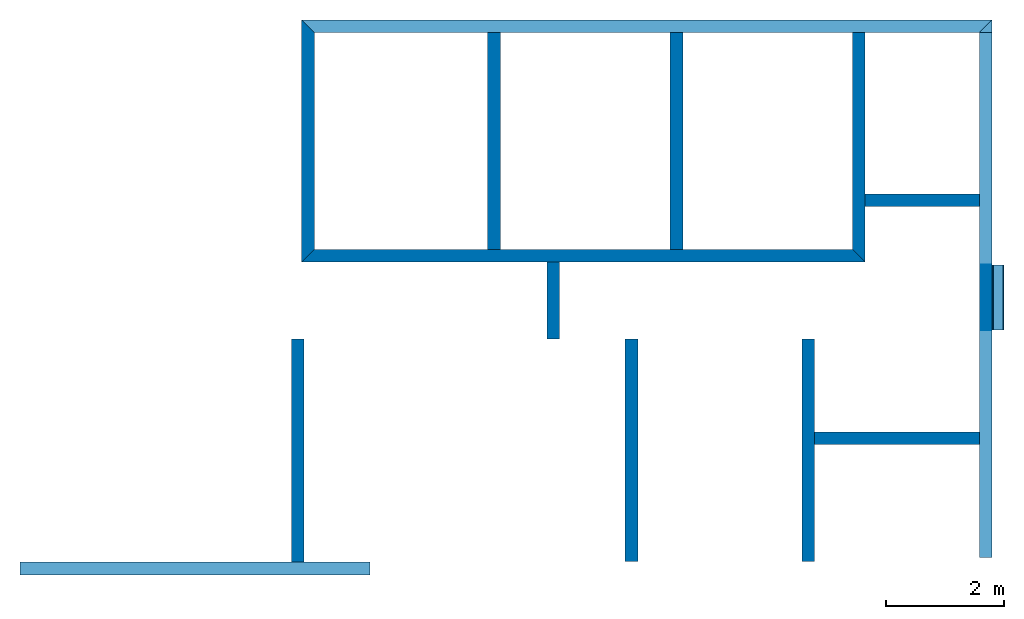
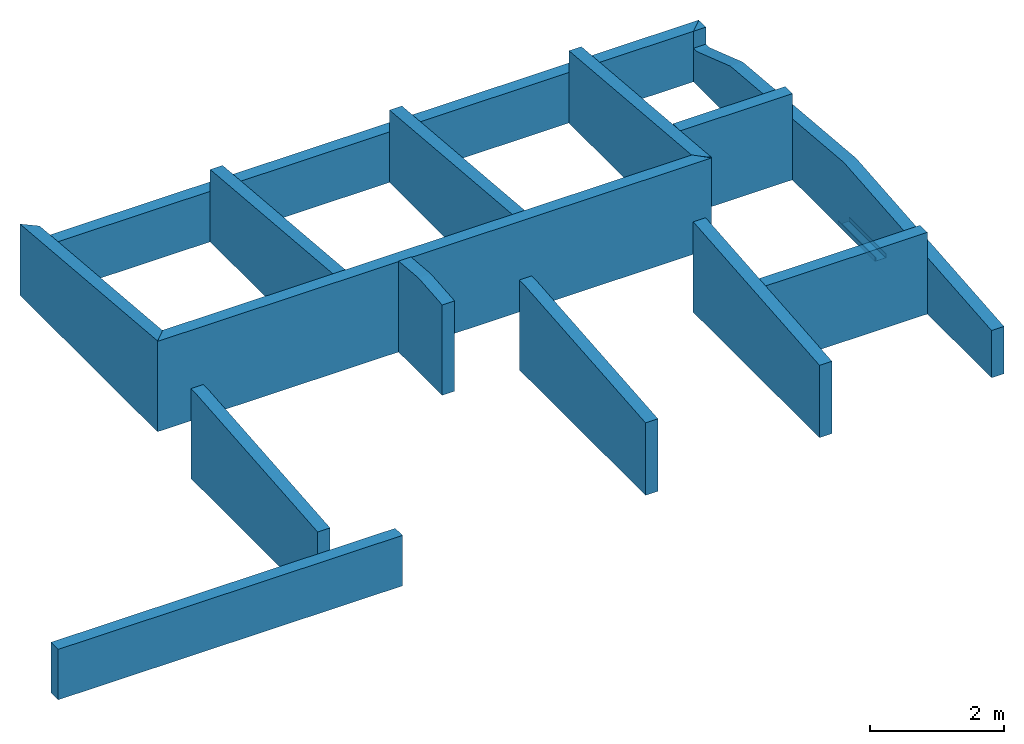
# One storey: 14 walls, 1 beam, 1 opening.
"""IFC2X3 building model written with IfcOpenShell, lengths in millimetres."""

import ifcopenshell
import ifcopenshell.guid

model = None  # the IFC model being written
_history = None  # IfcOwnerHistory: only IFC2X3 demands one
_inside = {}  # id of a spatial element -> (the spatial element, [elements in it])
_under = {}  # id of a project, library or spatial element -> (it, [spatial elements below it])
_declared = {}  # id of a project -> (the project, [libraries it declares])
_typed = {}  # id of a type object -> (the type object, [elements of that type])
_made_of = {}  # id of a material, layer set ... -> (it, [elements and type objects made of it])


def new_model(schema):
    """Start an empty IFC model of exactly this schema.

    Asked for "IFC4X3", IfcOpenShell would pick the latest addendum, in which some entities
    have other attributes; the version numbers below select the first issue.
    IFC2X3 requires an IfcOwnerHistory on every rooted entity: one is made here for all.
    """
    global model, _history
    if schema == "IFC4X3":
        model = ifcopenshell.file(schema_version=(4, 3, 0, 0))
    else:
        model = ifcopenshell.file(schema=schema)
    _inside.clear()
    _under.clear()
    _declared.clear()
    _typed.clear()
    _made_of.clear()
    _history = None
    if model.schema == "IFC2X3":
        org = make("IfcOrganization", Name="unknown")
        user = make(
            "IfcPersonAndOrganization",
            ThePerson=make("IfcPerson", FamilyName="unknown"),
            TheOrganization=org,
        )
        app = make(
            "IfcApplication",
            ApplicationDeveloper=org,
            Version="unknown",
            ApplicationFullName="unknown",
            ApplicationIdentifier="unknown",
        )
        _history = make(
            "IfcOwnerHistory",
            OwningUser=user,
            OwningApplication=app,
            ChangeAction="ADDED",
            CreationDate=0,
        )
    return model


def make(cls, **values):
    """One entity of the class cls with the attributes given. An attribute that is None is left unset."""
    return model.create_entity(
        cls, **{name: value for name, value in values.items() if value is not None}
    )


def entity(cls, *values):
    """Any entity or typed value of the class cls, its attributes in the order of the schema. None: left unset."""
    e = model.create_entity(cls)
    for i, value in enumerate(values):
        if value is not None:
            e[i] = value
    return e


def rooted(cls, **values):
    """An entity with a GlobalId (a new one), such as an element, a storey or a relation."""
    return make(cls, GlobalId=ifcopenshell.guid.new(), OwnerHistory=_history, **values)


def si_unit(unit_type, name, prefix=None):
    """IfcSIUnit, for example si_unit("LENGTHUNIT", "METRE", prefix="MILLI")."""
    return make("IfcSIUnit", UnitType=unit_type, Prefix=prefix, Name=name)


def converted_unit(unit_type, name, factor, base, dimensions=None, offset=None):
    """IfcConversionBasedUnit, such as the inch: factor (a typed value) times the base unit."""
    return make(
        "IfcConversionBasedUnit"
        if offset is None
        else "IfcConversionBasedUnitWithOffset",
        ConversionOffset=offset,
        Dimensions=None
        if dimensions is None
        else entity("IfcDimensionalExponents", *dimensions),
        UnitType=unit_type,
        Name=name,
        ConversionFactor=make(
            "IfcMeasureWithUnit", ValueComponent=factor, UnitComponent=base
        ),
    )


def money_unit(currency):
    """IfcMonetaryUnit."""
    return make("IfcMonetaryUnit", Currency=currency)


def assignment(units):
    """IfcUnitAssignment: the units of a project."""
    return None if units is None else make("IfcUnitAssignment", Units=units)


def point(xyz):
    """IfcCartesianPoint."""
    return None if xyz is None else make("IfcCartesianPoint", Coordinates=xyz)


def direction(xyz):
    """IfcDirection."""
    return None if xyz is None else make("IfcDirection", DirectionRatios=xyz)


def frame(location, z_axis=None, x_axis=None):
    """IfcAxis2Placement3D, a coordinate frame: its origin and axes. An axis left out is left unset."""
    return make(
        "IfcAxis2Placement3D",
        Location=point(location),
        Axis=direction(z_axis),
        RefDirection=direction(x_axis),
    )


def frame_2d(location, x_axis=None):
    """IfcAxis2Placement2D, a coordinate frame in the plane: its origin and x axis."""
    return make(
        "IfcAxis2Placement2D", Location=point(location), RefDirection=direction(x_axis)
    )


def origin_with_axes():
    """The frame at (0, 0, 0) with the z axis (0, 0, 1) and the x axis (1, 0, 0) written out."""
    return frame((0.0, 0.0, 0.0), z_axis=(0.0, 0.0, 1.0), x_axis=(1.0, 0.0, 0.0))


def place(relative_to, where):
    """IfcLocalPlacement: puts the frame where relative to a parent placement (None: the world)."""
    return make(
        "IfcLocalPlacement", PlacementRelTo=relative_to, RelativePlacement=where
    )


def context(
    kind, dimensions, precision=None, world=None, true_north=None, identifier=None
):
    """IfcGeometricRepresentationContext, for example the 3D "Model" context."""
    return make(
        "IfcGeometricRepresentationContext",
        ContextIdentifier=identifier,
        ContextType=kind,
        CoordinateSpaceDimension=dimensions,
        Precision=precision,
        WorldCoordinateSystem=world,
        TrueNorth=true_north,
    )


def subcontext(parent, identifier, kind, view, scale=None):
    """IfcGeometricRepresentationSubContext, for example "Body" below "Model"."""
    return make(
        "IfcGeometricRepresentationSubContext",
        ContextIdentifier=identifier,
        ContextType=kind,
        ParentContext=parent,
        TargetScale=scale,
        TargetView=view,
    )


def project(units=None, contexts=None):
    """IfcProject with its units and contexts."""
    return rooted(
        "IfcProject",
        Name="project",
        RepresentationContexts=contexts,
        UnitsInContext=assignment(units),
    )


def spatial(cls, under=None, at=None, **own):
    """A site, building, storey or space (cls), placed at a placement, below another one or the project."""
    s = rooted(cls, ObjectPlacement=at, **own)
    if under is not None:
        _under.setdefault(under.id(), (under, []))[1].append(s)
    return s


def polyline(points):
    """IfcPolyline through the points."""
    return make("IfcPolyline", Points=[point(p) for p in points])


def circle_curve(where, radius):
    """IfcCircle in the frame where."""
    return make("IfcCircle", Position=where, Radius=radius)


def parameter(value):
    """IfcParameterValue: where a trimmed curve begins or ends, as a parameter of its basis curve."""
    return model.create_entity("IfcParameterValue", value)


def trimmed(basis, trim1, trim2, sense, master):
    """IfcTrimmedCurve: the piece of a basis curve between two trims."""
    return make(
        "IfcTrimmedCurve",
        BasisCurve=basis,
        Trim1=trim1,
        Trim2=trim2,
        SenseAgreement=sense,
        MasterRepresentation=master,
    )


def segment(curve, same_sense, transition):
    """IfcCompositeCurveSegment."""
    return make(
        "IfcCompositeCurveSegment",
        Transition=transition,
        SameSense=same_sense,
        ParentCurve=curve,
    )


def composite_curve(segments, self_intersect=None):
    """IfcCompositeCurve: segments joined end to end."""
    return make("IfcCompositeCurve", Segments=segments, SelfIntersect=self_intersect)


def outline(outer, holes=None, kind="AREA"):
    """IfcArbitraryClosedProfileDef: a profile drawn as a closed curve; with holes, ...WithVoids."""
    if holes is None:
        return make("IfcArbitraryClosedProfileDef", ProfileType=kind, OuterCurve=outer)
    return make(
        "IfcArbitraryProfileDefWithVoids",
        ProfileType=kind,
        OuterCurve=outer,
        InnerCurves=holes,
    )


def extrude(swept, where, along, depth):
    """IfcExtrudedAreaSolid: the profile swept, set in the frame where, extruded along a direction by depth."""
    return make(
        "IfcExtrudedAreaSolid",
        SweptArea=swept,
        Position=where,
        ExtrudedDirection=direction(along),
        Depth=depth,
    )


def clip(a, b, op="DIFFERENCE"):
    """IfcBooleanClippingResult: the solid a cut by the half space b."""
    return make(
        "IfcBooleanClippingResult", Operator=op, FirstOperand=a, SecondOperand=b
    )


def halfspace(plane, agree):
    """IfcHalfSpaceSolid: all space on one side of the plane z = 0 of the frame plane."""
    return make(
        "IfcHalfSpaceSolid",
        BaseSurface=make("IfcPlane", Position=plane),
        AgreementFlag=agree,
    )


def shape(context_of_items, identifier, shape_type, items):
    """IfcShapeRepresentation: the items that make up one representation, for example the "Body"."""
    return make(
        "IfcShapeRepresentation",
        ContextOfItems=context_of_items,
        RepresentationIdentifier=identifier,
        RepresentationType=shape_type,
        Items=items,
    )


def material(Name=None, Category=None):
    """IfcMaterial."""
    return make("IfcMaterial", Name=Name, Category=Category)


def layer(
    of_material, thickness, ventilated=None, Name=None, Category=None, Priority=None
):
    """IfcMaterialLayer: one layer of a wall or slab, of a material (None: an air gap)."""
    return make(
        "IfcMaterialLayer",
        Material=of_material,
        LayerThickness=thickness,
        IsVentilated=ventilated,
        Name=Name,
        Category=Category,
        Priority=Priority,
    )


def layer_set(layers, Name=None):
    """IfcMaterialLayerSet."""
    return make("IfcMaterialLayerSet", MaterialLayers=layers, LayerSetName=Name)


def layer_usage(for_layer_set, set_direction, sense, offset, extent=None):
    """IfcMaterialLayerSetUsage: how a layer set lies in its element."""
    return make(
        "IfcMaterialLayerSetUsage",
        ForLayerSet=for_layer_set,
        LayerSetDirection=set_direction,
        DirectionSense=sense,
        OffsetFromReferenceLine=offset,
        ReferenceExtent=extent,
    )


def made_of(thing, what):
    """Note that an element or type object is made of a material, layer set ...; save() writes the relation."""
    if what is not None:
        _made_of.setdefault(what.id(), (what, []))[1].append(thing)
    return thing


def type_object(cls, material=None, **own):
    """A type object (cls), such as IfcWallType, which elements share."""
    return made_of(rooted(cls, **own), material)


def element(
    cls,
    number,
    at=None,
    inside=None,
    cuts=None,
    type_object=None,
    material=None,
    context=None,
    identifier="Body",
    shape_type=None,
    held_by="IfcProductDefinitionShape",
    body=None,
    shapes=None,
    **own,
):
    """One element of the class cls, such as IfcWall. Its Tag is "e" and its number.

    at: its placement. inside: the storey or other place that contains it. cuts: it is an
    opening in that element (IfcRelVoidsElement). A single representation is given by context,
    identifier, shape_type and body (its items); several are given by shapes. held_by: the class
    of the entity that holds the representations. save() writes the other relations.
    """
    e = rooted(cls, Tag="e%d" % number, ObjectPlacement=at, **own)
    if body is not None:
        shapes = [shape(context, identifier, shape_type, body)]
    if shapes is not None:
        e.Representation = make(held_by, Representations=shapes)
    if inside is not None:
        _inside.setdefault(inside.id(), (inside, []))[1].append(e)
    if cuts is not None:
        rooted(
            "IfcRelVoidsElement", RelatingBuildingElement=cuts, RelatedOpeningElement=e
        )
    if type_object is not None:
        _typed.setdefault(type_object.id(), (type_object, []))[1].append(e)
    return made_of(e, material)


def aggregate(whole, parts):
    """IfcRelAggregates: a whole, such as a stair, and the parts it consists of."""
    return rooted("IfcRelAggregates", RelatingObject=whole, RelatedObjects=parts)


def save(model, path):
    """Write the relations noted so far, then the file.

    IfcRelAggregates (storeys below a building ...), IfcRelContainedInSpatialStructure (elements
    in a storey), IfcRelDefinesByType, IfcRelAssociatesMaterial and IfcRelDeclares: one each for
    every whole, place, type object, material and project.
    """
    for whole, parts in _under.values():
        aggregate(whole, parts)
    for where, things in _inside.values():
        rooted(
            "IfcRelContainedInSpatialStructure",
            RelatedElements=things,
            RelatingStructure=where,
        )
    for kind, things in _typed.values():
        rooted("IfcRelDefinesByType", RelatedObjects=things, RelatingType=kind)
    for what, things in _made_of.values():
        rooted("IfcRelAssociatesMaterial", RelatedObjects=things, RelatingMaterial=what)
    for by, libraries in _declared.values():
        rooted("IfcRelDeclares", RelatingContext=by, RelatedDefinitions=libraries)
    model.write(path)


model = new_model("IFC2X3")

# Units and contexts
model_context = context("Model", 3, precision=1e-05, world=origin_with_axes(), true_north=direction((0.0, 1.0)))
body_context = subcontext(model_context, "Body", "Model", "MODEL_VIEW")
ifc_project = project(units=[si_unit("LENGTHUNIT", "METRE", prefix="MILLI"), si_unit("AREAUNIT", "SQUARE_METRE"), si_unit("VOLUMEUNIT", "CUBIC_METRE"), converted_unit("PLANEANGLEUNIT", "DEGREE", entity("IfcPlaneAngleMeasure", 0.0174532925199), si_unit("PLANEANGLEUNIT", "RADIAN"), dimensions=[0, 0, 0, 0, 0, 0, 0]), si_unit("SOLIDANGLEUNIT", "STERADIAN"), money_unit("USD"), converted_unit("TIMEUNIT", "Year", entity("IfcTimeMeasure", 31556926.0), si_unit("TIMEUNIT", "SECOND"), dimensions=[0, 0, 0, 0, 0, 0, 0]), si_unit("MASSUNIT", "GRAM"), si_unit("THERMODYNAMICTEMPERATUREUNIT", "DEGREE_CELSIUS"), si_unit("LUMINOUSINTENSITYUNIT", "LUMEN")], contexts=[model_context])

# Site, building, storey
site_placement = place(None, origin_with_axes())
site = spatial("IfcSite", under=ifc_project, at=site_placement, CompositionType="ELEMENT")
building_placement = place(site_placement, origin_with_axes())
building = spatial("IfcBuilding", under=site, at=building_placement, CompositionType="ELEMENT")
storey_placement = place(building_placement, frame((0.0, 0.0, 73100.0), z_axis=(0.0, 0.0, 1.0), x_axis=(1.0, 0.0, 0.0)))
storey = spatial("IfcBuildingStorey", under=building, at=storey_placement, CompositionType="ELEMENT", Elevation=73100.0)

# Beam
ifc_material_1 = material(Name="Metal - Steel 43-275")
beam_type = type_object("IfcBeamType", Name="PFC200x75x23 (1) 75 x 200", PredefinedType="NOTDEFINED")
beam_placement = place(storey_placement, frame((16618.0295383, 3022.47992169, -265.2), z_axis=(0.0, 0.0, 1.0), x_axis=(1.0, 0.0, 0.0)))
element("IfcBeam", 1, at=beam_placement, inside=storey, type_object=beam_type, material=ifc_material_1, Name="PFC-Parallel Flange Channels:PFC200x75x23", ObjectType="PFC-Parallel Flange Channels:PFC200x75x23", context=body_context, shape_type="SweptSolid", body=[
    extrude(outline(composite_curve([segment(polyline([(-40.2, -100.0), (34.8, -100.0), (34.8, 100.0), (-40.2, 100.0), (-40.2, 87.5), (16.8, 87.5)]), True, "CONTINUOUS"), segment(trimmed(circle_curve(frame_2d((16.8, 75.5), x_axis=(1.0, 0.0)), 12.0), [point((16.8, 87.5)), parameter(90.0)], [point((28.8, 75.5)), parameter(0.0)], False, "CARTESIAN"), True, "CONTINUOUS"), segment(polyline([(28.8, 75.5), (28.8, -75.5)]), True, "CONTINUOUS"), segment(trimmed(circle_curve(frame_2d((16.8, -75.5), x_axis=(0.0, -1.0)), 12.0), [point((28.8, -75.5)), parameter(90.0)], [point((16.8, -87.5)), parameter(0.0)], False, "CARTESIAN"), True, "CONTINUOUS"), segment(polyline([(16.8, -87.5), (-40.2, -87.5), (-40.2, -100.0)]), True, "CONTINUOUS")], self_intersect=False)), frame((0.0, 1110.0, 0.0), z_axis=(0.0, -1.0, 0.0), x_axis=(0.0, 0.0, -1.0)), (0.0, 0.0, 1.0), 1110.0),
])

# Wall, opening
ifc_material_2 = material(Name="Concrete Masonry Units _Low Density")
ifc_layer = layer(ifc_material_2, 215.0, ventilated="UNKNOWN")
ifc_layer_set = layer_set([ifc_layer], Name="Concrete Masonry Units _Low Density 215")
ifc_layer_usage_1 = layer_usage(ifc_layer_set, "AXIS2", "POSITIVE", -107.5)
wall_type = type_object("IfcWallType", Name="Basic Wall:215mm Thk Hollow Blockwork", PredefinedType="STANDARD")
wall_1_placement = place(storey_placement, frame((16405.5295383, -843.920063194, 0.0), z_axis=(0.0, 0.0, 1.0), x_axis=(0.0, 1.0, 0.0)))
wall_1 = element("IfcWallStandardCase", 2, at=wall_1_placement, inside=storey, type_object=wall_type, material=ifc_layer_usage_1, Name="Basic Wall:215mm Thk Hollow Blockwork", ObjectType="Basic Wall:215mm Thk Hollow Blockwork", context=body_context, shape_type="Clipping", body=[
    clip(clip(extrude(outline(polyline([(0.0, -107.5), (9136.4009626, -107.5), (8921.4009626, 107.5), (0.0, 107.5), (0.0, -107.5)])), origin_with_axes(), (0.0, 0.0, 1.0), 1252.62388144), halfspace(frame((-75.5023224038, 0.0, 855.964023814), z_axis=(0.08786619408, 0.0, -0.996132286365), x_axis=(0.0, 1.0, 0.0)), True)), halfspace(frame((111.83258991, 0.0, 1561.30751839), z_axis=(-0.0714444842585, 0.0, -0.997444577743), x_axis=(0.0, 1.0, 0.0)), True)),
])
opening_placement = place(wall_1_placement, frame((6725.15047374, 0.0, 611.674468851), z_axis=(0.0, 0.0, 1.0), x_axis=(1.0, 0.0, 0.0)))
element("IfcOpeningElement", 3, at=opening_placement, cuts=wall_1, Name="W-001", context=body_context, shape_type="SweptSolid", body=[
    extrude(outline(polyline([(2303.75048886, 310.925506495), (-2303.75048886, 640.949380819), (1091.73684114, 341.442455942), (2097.64952934, 6.86571866026e-05), (2196.25044023, 0.0), (2196.25050889, 310.925575152), (2303.75048886, 310.925506495)])), frame((0.0, 107.5, 0.0), z_axis=(0.0, -1.0, 0.0), x_axis=(1.0, 0.0, 0.0)), (0.0, 0.0, 1.0), 215.0),
])

# Walls
ifc_layer_usage_2 = layer_usage(ifc_layer_set, "AXIS2", "POSITIVE", -107.5)
wall_2_placement = place(storey_placement, frame((13393.279151, 1184.98008426, 0.0), z_axis=(0.0, 0.0, 1.0), x_axis=(1.0, 0.0, 0.0)))
element("IfcWallStandardCase", 4, at=wall_2_placement, inside=storey, type_object=wall_type, material=ifc_layer_usage_2, Name="Basic Wall:215mm Thk Hollow Blockwork", ObjectType="Basic Wall:215mm Thk Hollow Blockwork", context=body_context, shape_type="SweptSolid", body=[
    extrude(outline(polyline([(107.5, -107.5), (2904.7503873, -107.5), (2904.7503873, 107.5), (107.5, 107.5), (107.5, -107.5)])), origin_with_axes(), (0.0, 0.0, 1.0), 1492.38094849),
])
ifc_layer_usage_3 = layer_usage(ifc_layer_set, "AXIS2", "POSITIVE", -107.5)
wall_3_placement = place(storey_placement, frame((14250.7793532, 5227.48003424, 0.0), z_axis=(0.0, 0.0, 1.0), x_axis=(1.0, 0.0, 0.0)))
element("IfcWallStandardCase", 5, at=wall_3_placement, inside=storey, type_object=wall_type, material=ifc_layer_usage_3, Name="Basic Wall:215mm Thk Hollow Blockwork", ObjectType="Basic Wall:215mm Thk Hollow Blockwork", context=body_context, shape_type="SweptSolid", body=[
    extrude(outline(polyline([(107.5, -107.5), (2047.2501851, -107.5), (2047.2501851, 107.5), (107.5, 107.5), (107.5, -107.5)])), origin_with_axes(), (0.0, 0.0, 1.0), 1574.91211888),
])
ifc_layer_usage_4 = layer_usage(ifc_layer_set, "AXIS2", "POSITIVE", -107.5)
wall_4_placement = place(storey_placement, frame((11150.7793535, 4284.98089941, 0.0), z_axis=(0.0, 0.0, 1.0), x_axis=(0.0, 1.0, 0.0)))
element("IfcWallStandardCase", 6, at=wall_4_placement, inside=storey, type_object=wall_type, material=ifc_layer_usage_4, Name="Basic Wall:215mm Thk Hollow Blockwork", ObjectType="Basic Wall:215mm Thk Hollow Blockwork", context=body_context, shape_type="Clipping", body=[
    clip(extrude(outline(polyline([(107.5, -107.5), (3792.5, -107.5), (3792.5, 107.5), (107.5, 107.5), (107.5, -107.5)])), origin_with_axes(), (0.0, 0.0, 1.0), 1643.81080398), halfspace(frame((143.538958546, 0.0, 1640.65780367), z_axis=(-0.0871557427477, 0.0, -0.996194698092), x_axis=(0.0, 1.0, 0.0)), True)),
])
ifc_layer_usage_5 = layer_usage(ifc_layer_set, "AXIS2", "POSITIVE", -107.5)
wall_5_placement = place(storey_placement, frame((4888.27947463, 8184.98089941, 0.0), z_axis=(0.0, 0.0, 1.0), x_axis=(1.0, 0.0, 0.0)))
element("IfcWallStandardCase", 7, at=wall_5_placement, inside=storey, type_object=wall_type, material=ifc_layer_usage_5, Name="Basic Wall:215mm Thk Hollow Blockwork", ObjectType="Basic Wall:215mm Thk Hollow Blockwork", context=body_context, shape_type="SweptSolid", body=[
    extrude(outline(polyline([(107.5, -107.5), (11409.7500637, -107.5), (11624.7500637, 107.5), (-107.5, 107.5), (107.5, -107.5)])), origin_with_axes(), (0.0, 0.0, 1.0), 922.6),
])
ifc_layer_usage_6 = layer_usage(ifc_layer_set, "AXIS2", "POSITIVE", -107.5)
wall_6_placement = place(storey_placement, frame((8050.77935353, 4284.98089941, 0.0), z_axis=(0.0, 0.0, 1.0), x_axis=(0.0, 1.0, 0.0)))
element("IfcWallStandardCase", 8, at=wall_6_placement, inside=storey, type_object=wall_type, material=ifc_layer_usage_6, Name="Basic Wall:215mm Thk Hollow Blockwork", ObjectType="Basic Wall:215mm Thk Hollow Blockwork", context=body_context, shape_type="Clipping", body=[
    clip(extrude(outline(polyline([(107.5, -107.5), (3792.5, -107.5), (3792.5, 107.5), (107.5, 107.5), (107.5, -107.5)])), origin_with_axes(), (0.0, 0.0, 1.0), 1643.81080398), halfspace(frame((143.538958546, 0.0, 1640.65780367), z_axis=(-0.0871557427477, 0.0, -0.996194698092), x_axis=(0.0, 1.0, 0.0)), True)),
])
ifc_layer_usage_7 = layer_usage(ifc_layer_set, "AXIS2", "POSITIVE", -107.5)
wall_7_placement = place(storey_placement, frame((4888.27947463, 4284.98089941, 0.0), z_axis=(0.0, 0.0, 1.0), x_axis=(1.0, 0.0, 0.0)))
element("IfcWallStandardCase", 9, at=wall_7_placement, inside=storey, type_object=wall_type, material=ifc_layer_usage_7, Name="Basic Wall:215mm Thk Hollow Blockwork", ObjectType="Basic Wall:215mm Thk Hollow Blockwork", context=body_context, shape_type="SweptSolid", body=[
    extrude(outline(polyline([(-107.5, -107.5), (9469.99987857, -107.5), (9254.99987857, 107.5), (107.5, 107.5), (-107.5, -107.5)])), origin_with_axes(), (0.0, 0.0, 1.0), 1651.58644892),
])
ifc_layer_usage_8 = layer_usage(ifc_layer_set, "AXIS2", "POSITIVE", -107.5)
wall_8_placement = place(storey_placement, frame((14250.7793532, 4284.98089941, 0.0), z_axis=(0.0, 0.0, 1.0), x_axis=(0.0, 1.0, 0.0)))
element("IfcWallStandardCase", 10, at=wall_8_placement, inside=storey, type_object=wall_type, material=ifc_layer_usage_8, Name="Basic Wall:215mm Thk Hollow Blockwork", ObjectType="Basic Wall:215mm Thk Hollow Blockwork", context=body_context, shape_type="Clipping", body=[
    clip(extrude(outline(polyline([(-107.5, -107.5), (3792.5, -107.5), (3792.5, 107.5), (107.5, 107.5), (-107.5, -107.5)])), origin_with_axes(), (0.0, 0.0, 1.0), 1662.62086664), halfspace(frame((143.538958546, 0.0, 1640.65780367), z_axis=(-0.0871557427477, 0.0, -0.996194698092), x_axis=(0.0, 1.0, 0.0)), True)),
])
ifc_layer_usage_9 = layer_usage(ifc_layer_set, "AXIS2", "POSITIVE", -107.5)
wall_9_placement = place(storey_placement, frame((4888.27947463, 8184.98089941, 0.0), z_axis=(0.0, 0.0, 1.0), x_axis=(0.0, -1.0, 0.0)))
element("IfcWallStandardCase", 11, at=wall_9_placement, inside=storey, type_object=wall_type, material=ifc_layer_usage_9, Name="Basic Wall:215mm Thk Hollow Blockwork", ObjectType="Basic Wall:215mm Thk Hollow Blockwork", context=body_context, shape_type="Clipping", body=[
    clip(extrude(outline(polyline([(-107.5, -107.5), (4007.5, -107.5), (3792.5, 107.5), (107.5, 107.5), (-107.5, -107.5)])), origin_with_axes(), (0.0, 0.0, 1.0), 1662.62086664), halfspace(frame((-113.91407692, 0.0, 1302.04385722), z_axis=(0.0871557427477, 0.0, -0.996194698092), x_axis=(0.0, 1.0, 0.0)), True)),
])
ifc_layer_usage_10 = layer_usage(ifc_layer_set, "AXIS2", "POSITIVE", -107.5)
wall_10_placement = place(storey_placement, frame((10387.3729721, -910.020060799, 0.0), z_axis=(0.0, 0.0, 1.0), x_axis=(0.0, 1.0, 0.0)))
element("IfcWallStandardCase", 12, at=wall_10_placement, inside=storey, type_object=wall_type, material=ifc_layer_usage_10, Name="Basic Wall:215mm Thk Hollow Blockwork", ObjectType="Basic Wall:215mm Thk Hollow Blockwork", context=body_context, shape_type="Clipping", body=[
    clip(extrude(outline(polyline([(0.0, -107.5), (3780.00062234, -107.5), (3780.00062234, 107.5), (0.0, 107.5), (0.0, -107.5)])), origin_with_axes(), (0.0, 0.0, 1.0), 1643.62700278), halfspace(frame((-114.80964864, 0.0, 1312.28028882), z_axis=(0.0871557427477, 0.0, -0.996194698092), x_axis=(0.0, 1.0, 0.0)), True)),
])
ifc_layer_usage_11 = layer_usage(ifc_layer_set, "AXIS2", "POSITIVE", -107.5)
wall_11_placement = place(storey_placement, frame((4713.27927124, -1030.0700608, 0.0), z_axis=(0.0, 0.0, 1.0), x_axis=(0.0, 1.0, 0.0)))
element("IfcWallStandardCase", 13, at=wall_11_placement, inside=storey, type_object=wall_type, material=ifc_layer_usage_11, Name="Basic Wall:215mm Thk Hollow Blockwork", ObjectType="Basic Wall:215mm Thk Hollow Blockwork", context=body_context, shape_type="Clipping", body=[
    clip(extrude(outline(polyline([(107.5, -107.5), (3900.05062234, -107.5), (3900.05062234, 107.5), (107.5, 107.5), (107.5, -107.5)])), origin_with_axes(), (0.0, 0.0, 1.0), 1643.6572673), halfspace(frame((-113.631792494, 0.0, 1303.01029735), z_axis=(0.0868774038846, 0.0, -0.996219010406), x_axis=(0.0, 1.0, 0.0)), True)),
])
ifc_layer_usage_12 = layer_usage(ifc_layer_set, "AXIS2", "POSITIVE", -107.5)
wall_12_placement = place(storey_placement, frame((13393.279151, 2869.98056155, 0.0), z_axis=(0.0, 0.0, 1.0), x_axis=(0.0, -1.0, 0.0)))
element("IfcWallStandardCase", 14, at=wall_12_placement, inside=storey, type_object=wall_type, material=ifc_layer_usage_12, Name="Basic Wall:215mm Thk Hollow Blockwork", ObjectType="Basic Wall:215mm Thk Hollow Blockwork", context=body_context, shape_type="Clipping", body=[
    clip(extrude(outline(polyline([(0.0, -107.5), (3780.00062234, -107.5), (3780.00062234, 107.5), (0.0, 107.5), (0.0, -107.5)])), origin_with_axes(), (0.0, 0.0, 1.0), 1662.43706544), halfspace(frame((143.523000174, 0.0, 1640.47539864), z_axis=(-0.0871557427477, 0.0, -0.996194698092), x_axis=(0.0, 1.0, 0.0)), True)),
])
ifc_layer_usage_13 = layer_usage(ifc_layer_set, "AXIS2", "POSITIVE", -107.5)
wall_13_placement = place(storey_placement, frame((-6.72084898817, -1030.0700608, 0.0), z_axis=(0.0, 0.0, 1.0), x_axis=(1.0, 0.0, 0.0)))
element("IfcWallStandardCase", 15, at=wall_13_placement, inside=storey, type_object=wall_type, material=ifc_layer_usage_13, Name="Basic Wall:215mm Thk Hollow Blockwork", ObjectType="Basic Wall:215mm Thk Hollow Blockwork", context=body_context, shape_type="SweptSolid", body=[
    extrude(outline(polyline([(0.0, -107.5), (5952.91663758, -107.5), (5952.91663758, 107.5), (0.0, 107.5), (0.0, -107.5)])), origin_with_axes(), (0.0, 0.0, 1.0), 922.6),
])
ifc_layer_usage_14 = layer_usage(ifc_layer_set, "AXIS2", "POSITIVE", -107.5)
wall_14_placement = place(storey_placement, frame((9054.17084747, 2869.98056155, 0.0), z_axis=(0.0, 0.0, 1.0), x_axis=(0.0, 1.0, 0.0)))
element("IfcWallStandardCase", 16, at=wall_14_placement, inside=storey, type_object=wall_type, material=ifc_layer_usage_14, Name="Basic Wall:215mm Thk Hollow Blockwork", ObjectType="Basic Wall:215mm Thk Hollow Blockwork", context=body_context, shape_type="Clipping", body=[
    clip(clip(extrude(outline(polyline([(0.0, -107.5), (1307.50033786, -107.5), (1307.50033786, 107.5), (0.0, 107.5), (0.0, -107.5)])), origin_with_axes(), (0.0, 0.0, 1.0), 1715.02217894), halfspace(frame((154.287475856, 0.0, 1763.5139187), z_axis=(-0.0871557427477, 0.0, -0.996194698092), x_axis=(0.0, 1.0, 0.0)), True)), halfspace(frame((-143.523000174, 0.0, 1640.47539864), z_axis=(0.0871557427477, 0.0, -0.996194698092), x_axis=(0.0, 1.0, 0.0)), True)),
])

save(model, "model.ifc")
